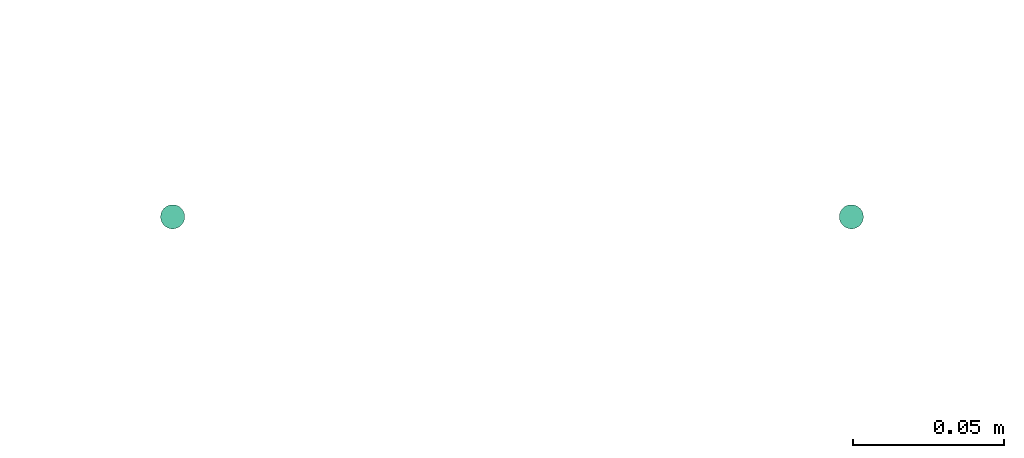
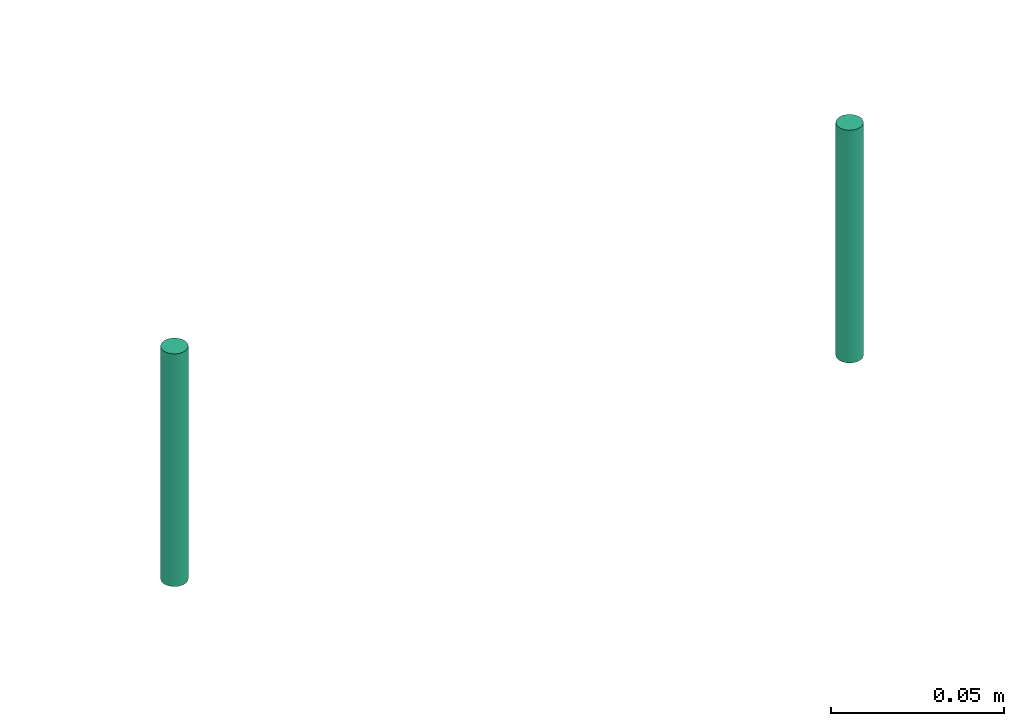
# One storey, part 68 of 89: 2 flow segments.
"""IFC2X3 building model written with IfcOpenShell, lengths in millimetres."""

from ifc_helpers import new_model, entity, si_unit, converted_unit, derived_unit, direction, frame, origin, origin_2d_with_axis, place, context, subcontext, project, spatial, circle, extrude, type_object, element, save


model = new_model("IFC2X3")

# Units and contexts
model_context = context("Model", 3, precision=0.01, world=origin(), true_north=direction((6.12303176911189e-17, 1.0)))
body_context = subcontext(model_context, "Body", "Model", "MODEL_VIEW")
ifc_project = project(units=[si_unit("LENGTHUNIT", "METRE", prefix="MILLI"), si_unit("AREAUNIT", "SQUARE_METRE"), si_unit("VOLUMEUNIT", "CUBIC_METRE"), converted_unit("PLANEANGLEUNIT", "DEGREE", entity("IfcRatioMeasure", 0.0174532925199433), si_unit("PLANEANGLEUNIT", "RADIAN"), dimensions=[0, 0, 0, 0, 0, 0, 0]), si_unit("MASSUNIT", "GRAM", prefix="KILO"), derived_unit("MASSDENSITYUNIT", [(si_unit("MASSUNIT", "GRAM", prefix="KILO"), 1), (si_unit("LENGTHUNIT", "METRE"), -3)]), derived_unit("MOMENTOFINERTIAUNIT", [(si_unit("LENGTHUNIT", "METRE"), 4)]), si_unit("TIMEUNIT", "SECOND"), si_unit("FREQUENCYUNIT", "HERTZ"), si_unit("THERMODYNAMICTEMPERATUREUNIT", "DEGREE_CELSIUS"), derived_unit("THERMALTRANSMITTANCEUNIT", [(si_unit("MASSUNIT", "GRAM", prefix="KILO"), 1), (si_unit("THERMODYNAMICTEMPERATUREUNIT", "KELVIN"), -1), (si_unit("TIMEUNIT", "SECOND"), -3)]), derived_unit("VOLUMETRICFLOWRATEUNIT", [(si_unit("LENGTHUNIT", "METRE"), 3), (si_unit("TIMEUNIT", "SECOND"), -1)]), derived_unit("MASSFLOWRATEUNIT", [(si_unit("MASSUNIT", "GRAM", prefix="KILO"), 1), (si_unit("TIMEUNIT", "SECOND"), -1)]), derived_unit("ROTATIONALFREQUENCYUNIT", [(si_unit("TIMEUNIT", "SECOND"), -1)]), si_unit("ELECTRICCURRENTUNIT", "AMPERE"), si_unit("ELECTRICVOLTAGEUNIT", "VOLT"), si_unit("POWERUNIT", "WATT"), si_unit("FORCEUNIT", "NEWTON", prefix="KILO"), si_unit("ILLUMINANCEUNIT", "LUX"), si_unit("LUMINOUSFLUXUNIT", "LUMEN"), si_unit("LUMINOUSINTENSITYUNIT", "CANDELA"), derived_unit("USERDEFINED", [(si_unit("MASSUNIT", "GRAM", prefix="KILO"), -1), (si_unit("LENGTHUNIT", "METRE"), -2), (si_unit("TIMEUNIT", "SECOND"), 3), (si_unit("LUMINOUSFLUXUNIT", "LUMEN"), 1)]), derived_unit("LINEARVELOCITYUNIT", [(si_unit("LENGTHUNIT", "METRE"), 1), (si_unit("TIMEUNIT", "SECOND"), -1)]), si_unit("PRESSUREUNIT", "PASCAL"), derived_unit("USERDEFINED", [(si_unit("LENGTHUNIT", "METRE"), -2), (si_unit("MASSUNIT", "GRAM", prefix="KILO"), 1), (si_unit("TIMEUNIT", "SECOND"), -2)]), derived_unit("LINEARFORCEUNIT", [(si_unit("MASSUNIT", "GRAM", prefix="KILO"), 1), (si_unit("LENGTHUNIT", "METRE"), 1), (si_unit("TIMEUNIT", "SECOND"), -2), (si_unit("LENGTHUNIT", "METRE"), -1)]), derived_unit("PLANARFORCEUNIT", [(si_unit("MASSUNIT", "GRAM", prefix="KILO"), 1), (si_unit("LENGTHUNIT", "METRE"), 1), (si_unit("TIMEUNIT", "SECOND"), -2), (si_unit("LENGTHUNIT", "METRE"), -2)])], contexts=[model_context])

# Site, building, storey
site_placement = place(None, frame((0.0, -0.00077364408347762, 0.0)))
site = spatial("IfcSite", under=ifc_project, at=site_placement, CompositionType="ELEMENT")
building_placement = place(site_placement, origin())
building = spatial("IfcBuilding", under=site, at=building_placement, CompositionType="ELEMENT")
storey_placement = place(building_placement, frame((0.0, 0.0, 24000.0)))
storey = spatial("IfcBuildingStorey", under=building, at=storey_placement, CompositionType="ELEMENT", Elevation=24000.0)

# Flow segments
pipe_segment_type = type_object("IfcPipeSegmentType", PredefinedType="NOTDEFINED")
flow_segment_1_placement = place(storey_placement, frame((34390.4558773093, 9269.40472776439, -5537.0)))
element("IfcFlowSegment", 1, at=flow_segment_1_placement, inside=storey, type_object=pipe_segment_type, context=body_context, shape_type="SweptSolid", body=[
    extrude(circle(Radius=4.0, at=origin_2d_with_axis()), frame((5.59527223591499, 5.59527223591607, 0.0), z_axis=(0.0, 0.0, 1.0), x_axis=(-1.0, 0.0, 0.0)), (0.0, 0.0, 1.0), 82.0000000000225),
])
flow_segment_2_placement = place(storey_placement, frame((34165.4558773093, 9269.40472776439, -5537.0)))
element("IfcFlowSegment", 2, at=flow_segment_2_placement, inside=storey, type_object=pipe_segment_type, context=body_context, shape_type="SweptSolid", body=[
    extrude(circle(Radius=4.0, at=origin_2d_with_axis()), frame((5.59527223591499, 5.59527223591607, 0.0), z_axis=(0.0, 0.0, 1.0), x_axis=(-1.0, 0.0, 0.0)), (0.0, 0.0, 1.0), 82.0000000000203),
])

save(model, "model.ifc")
